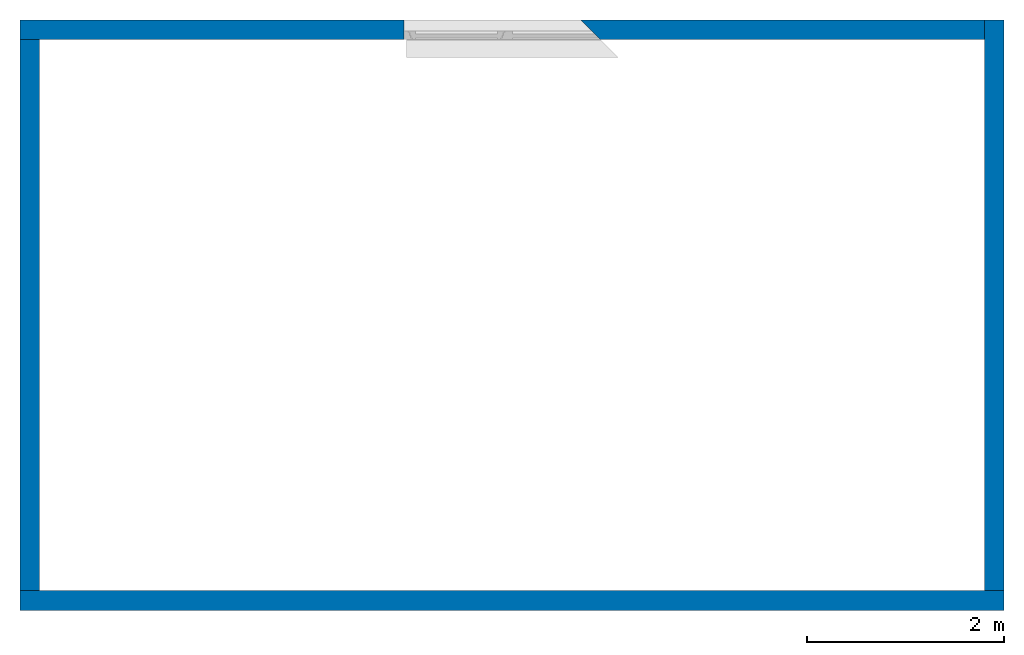
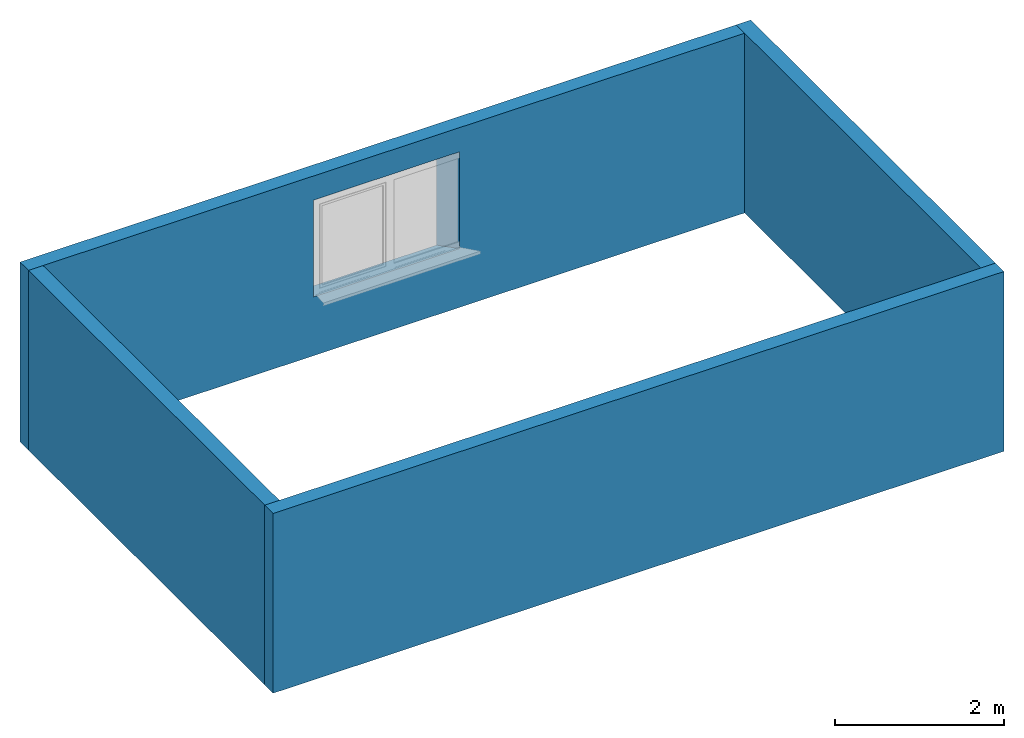
# One storey, part 1 of 2: 4 walls, 1 opening.
"""IFC2X3 building model written with IfcOpenShell, lengths in metres."""

from ifc_helpers import new_model, entity, si_unit, converted_unit, derived_unit, direction, frame, frame_2d, origin, place, context, subcontext, project, spatial, rectangle, extrude, faceted_brep, material, layer, layer_set, layer_usage, type_object, element, save


model = new_model("IFC2X3")

# Units and contexts
model_context = context("Model", 3, precision=1e-05, world=origin(), true_north=direction((6.12303176911189e-17, 1.0)))
body_context = subcontext(model_context, "Body", "Model", "MODEL_VIEW")
ifc_project = project(units=[si_unit("LENGTHUNIT", "METRE"), si_unit("AREAUNIT", "SQUARE_METRE"), si_unit("VOLUMEUNIT", "CUBIC_METRE"), converted_unit("PLANEANGLEUNIT", "DEGREE", entity("IfcRatioMeasure", 0.0174532925199433), si_unit("PLANEANGLEUNIT", "RADIAN"), dimensions=[0, 0, 0, 0, 0, 0, 0]), si_unit("MASSUNIT", "GRAM", prefix="KILO"), derived_unit("MASSDENSITYUNIT", [(si_unit("MASSUNIT", "GRAM", prefix="KILO"), 1), (si_unit("LENGTHUNIT", "METRE"), -3)]), si_unit("TIMEUNIT", "SECOND"), si_unit("FREQUENCYUNIT", "HERTZ"), si_unit("THERMODYNAMICTEMPERATUREUNIT", "DEGREE_CELSIUS"), derived_unit("THERMALTRANSMITTANCEUNIT", [(si_unit("MASSUNIT", "GRAM", prefix="KILO"), 1), (si_unit("THERMODYNAMICTEMPERATUREUNIT", "KELVIN"), -1), (si_unit("TIMEUNIT", "SECOND"), -3)]), derived_unit("VOLUMETRICFLOWRATEUNIT", [(si_unit("LENGTHUNIT", "METRE"), 3), (si_unit("TIMEUNIT", "SECOND"), -1)]), si_unit("ELECTRICCURRENTUNIT", "AMPERE"), si_unit("ELECTRICVOLTAGEUNIT", "VOLT"), si_unit("POWERUNIT", "WATT"), si_unit("FORCEUNIT", "NEWTON", prefix="KILO"), si_unit("ILLUMINANCEUNIT", "LUX"), si_unit("LUMINOUSFLUXUNIT", "LUMEN"), si_unit("LUMINOUSINTENSITYUNIT", "CANDELA"), derived_unit("USERDEFINED", [(si_unit("MASSUNIT", "GRAM", prefix="KILO"), -1), (si_unit("LENGTHUNIT", "METRE"), -2), (si_unit("TIMEUNIT", "SECOND"), 3), (si_unit("LUMINOUSFLUXUNIT", "LUMEN"), 1)]), derived_unit("LINEARVELOCITYUNIT", [(si_unit("LENGTHUNIT", "METRE"), 1), (si_unit("TIMEUNIT", "SECOND"), -1)]), si_unit("PRESSUREUNIT", "PASCAL"), derived_unit("USERDEFINED", [(si_unit("LENGTHUNIT", "METRE"), -2), (si_unit("MASSUNIT", "GRAM", prefix="KILO"), 1), (si_unit("TIMEUNIT", "SECOND"), -2)])], contexts=[model_context])

# Site, building, storey
site_placement = place(None, frame((4.52949330505959e-05, 1.90131286899941e-05, 0.0)))
site = spatial("IfcSite", under=ifc_project, at=site_placement, CompositionType="ELEMENT")
building_placement = place(site_placement, origin())
building = spatial("IfcBuilding", under=site, at=building_placement, CompositionType="ELEMENT")
storey_placement = place(building_placement, origin())
storey = spatial("IfcBuildingStorey", under=building, at=storey_placement, CompositionType="ELEMENT", Elevation=0.0)

# Walls
ifc_material = material(Name="Ortbeton - bewehrt Verputzt")
ifc_layer = layer(ifc_material, 0.2)
ifc_layer_set = layer_set([ifc_layer], Name="STB 200")
ifc_layer_usage_1 = layer_usage(ifc_layer_set, "AXIS2", "NEGATIVE", 0.1)
wall_type = type_object("IfcWallType", Name="STB 200", PredefinedType="STANDARD", material=ifc_layer_set)
wall_1_placement = place(storey_placement, frame((-4.5294933051517e-05, 0.09998098687131, 0.0)))
element("IfcWallStandardCase", 1, at=wall_1_placement, inside=storey, type_object=wall_type, material=ifc_layer_usage_1, Name="STB 200", ObjectType="STB 200", context=body_context, shape_type="SweptSolid", body=[
    extrude(rectangle(XDim=10.0, YDim=0.2, at=frame_2d((5.0, 0.0), x_axis=(-1.0, 0.0))), origin(), (0.0, 0.0, 1.0), 2.6),
])
ifc_layer_usage_2 = layer_usage(ifc_layer_set, "AXIS2", "NEGATIVE", 0.1)
wall_2_placement = place(storey_placement, frame((9.89995470506695, 0.199980986871294, 0.0), z_axis=(0.0, 0.0, 1.0), x_axis=(0.0, 1.0, 0.0)))
element("IfcWallStandardCase", 2, at=wall_2_placement, inside=storey, type_object=wall_type, material=ifc_layer_usage_2, Name="STB 200", ObjectType="STB 200", context=body_context, shape_type="SweptSolid", body=[
    extrude(rectangle(XDim=5.8, YDim=0.199999999999998, at=frame_2d((2.9, 0.0), x_axis=(-1.0, 0.0))), origin(), (0.0, 0.0, 1.0), 2.6),
])

# Wall, opening
ifc_layer_usage_3 = layer_usage(ifc_layer_set, "AXIS2", "NEGATIVE", 0.1)
wall_3_placement = place(storey_placement, frame((9.79995470506695, 5.8999809868713, 0.0), z_axis=(0.0, 0.0, 1.0), x_axis=(-1.0, 0.0, 0.0)))
wall_3 = element("IfcWallStandardCase", 3, at=wall_3_placement, inside=storey, type_object=wall_type, material=ifc_layer_usage_3, Name="STB 200", ObjectType="STB 200", context=body_context, shape_type="SweptSolid", body=[
    extrude(rectangle(XDim=9.79999999999999, YDim=0.2, at=frame_2d((4.9, 2.22044604925031e-16), x_axis=(-1.0, 0.0))), origin(), (0.0, 0.0, 1.0), 2.6),
])
opening_placement = place(wall_3_placement, frame((5.89999999999999, 0.260000000000955, 0.85), z_axis=(0.0, 0.0, 1.0), x_axis=(-1.0, 0.0, 0.0)))
element("IfcOpeningElement", 4, at=opening_placement, cuts=wall_3, Name="STB 200", ObjectType="Opening", context=body_context, shape_type="Brep", body=[
    faceted_brep([(2.0, 0.159999999999999, 1.4), (1.79999999999903, 0.360000000000965, 1.4), (0.0, 0.360000000000971, 1.4), (0.0, 0.160000000000006, 1.4), (2.0, 0.159999999999999, 0.0), (0.0, 0.160000000000006, 0.0), (0.0, 0.360000000000971, 0.0), (1.79999999999903, 0.360000000000965, 0.0), (2.0, 0.159999999999998, 1.37000000000001), (2.15999999999993, 0.0, 1.37), (2.15999999999996, 0.0, 0.00999999999999922), (2.0, 0.159999999999997, 0.0200000000000026), (0.0299999999999997, 0.160000000000005, 0.0200000000000026), (0.0299999999999997, 0.160000000000005, 1.37000000000001), (0.0299999999999482, 0.0, 1.37), (0.0299999999999482, 0.0, 0.00999999999999922)], [[[0, 1, 2, 3]], [[4, 5, 6, 7]], [[0, 8, 9, 10, 11, 4, 7, 1]], [[1, 7, 6, 2]], [[2, 6, 5, 3]], [[3, 5, 4, 11, 12, 13, 8, 0]], [[14, 15, 10, 9]], [[14, 13, 12, 15]], [[15, 12, 11, 10]], [[9, 8, 13, 14]]]),
])

# Wall
ifc_layer_usage_4 = layer_usage(ifc_layer_set, "AXIS2", "NEGATIVE", 0.1)
wall_4_placement = place(storey_placement, frame((0.0999547050669589, 5.79998098687133, 0.0), z_axis=(0.0, 0.0, 1.0), x_axis=(0.0, -1.0, 0.0)))
element("IfcWallStandardCase", 5, at=wall_4_placement, inside=storey, type_object=wall_type, material=ifc_layer_usage_4, Name="STB 200", ObjectType="STB 200", context=body_context, shape_type="SweptSolid", body=[
    extrude(rectangle(XDim=5.60000000000002, YDim=0.2, at=frame_2d((2.80000000000001, -6.93889390390723e-18), x_axis=(-1.0, 0.0))), origin(), (0.0, 0.0, 1.0), 2.6),
])

save(model, "model.ifc")
